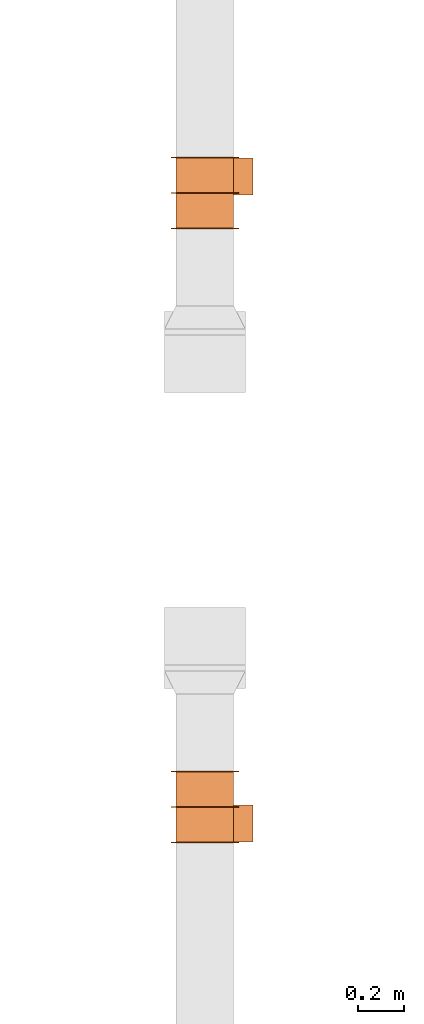
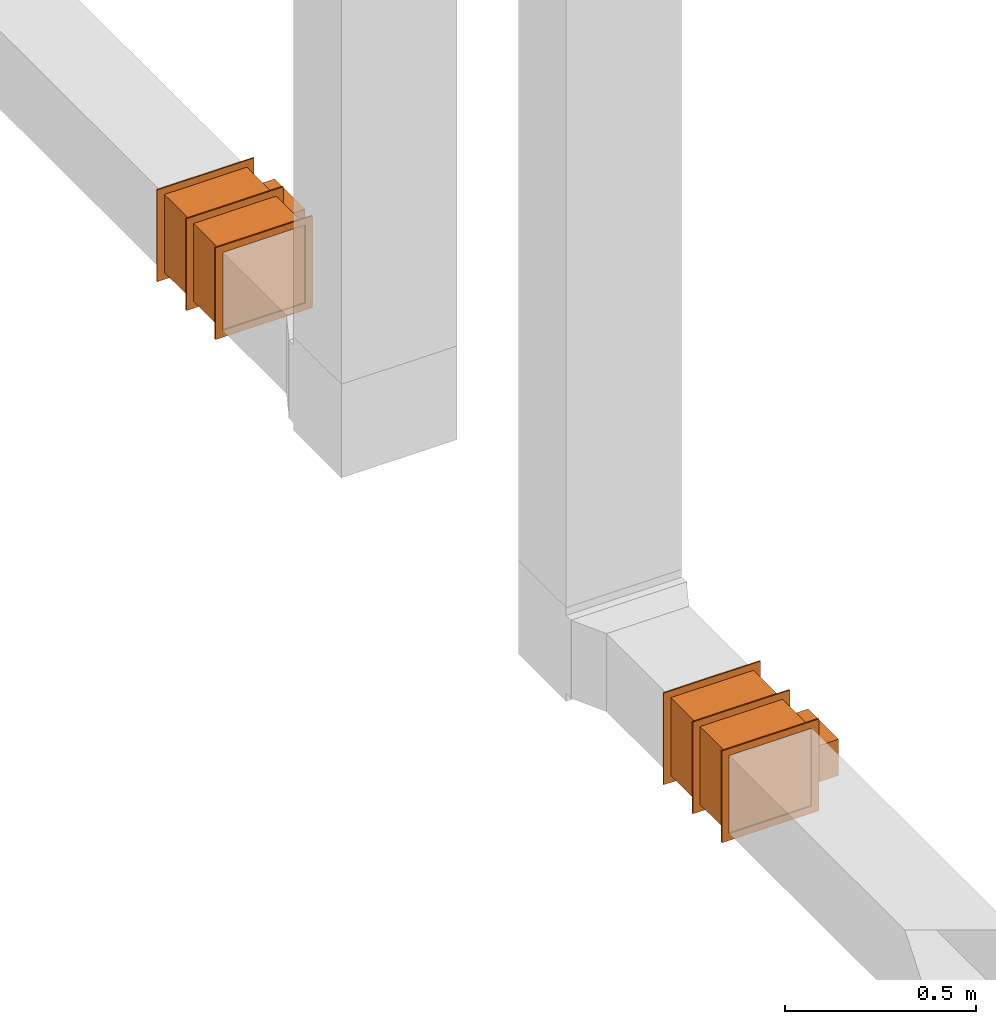
# One storey, part 3 of 3: 2 proxies.
"""IFC2X3 building model written with IfcOpenShell, lengths in millimetres."""

from ifc_helpers import new_model, entity, si_unit, converted_unit, derived_unit, direction, frame, frame_2d, origin, origin_2d_with_axis, place, context, subcontext, project, spatial, polyline, rectangle, outline, extrude, source, transform, mapped, type_object, type_shapes, element, save


model = new_model("IFC2X3")

# Units and contexts
model_context = context("Model", 3, precision=0.01, world=origin(), true_north=direction((6.12303176911189e-17, 1.0)))
body_context = subcontext(model_context, "Body", "Model", "MODEL_VIEW")
ifc_project = project(units=[si_unit("LENGTHUNIT", "METRE", prefix="MILLI"), si_unit("AREAUNIT", "SQUARE_METRE"), si_unit("VOLUMEUNIT", "CUBIC_METRE"), converted_unit("PLANEANGLEUNIT", "DEGREE", entity("IfcRatioMeasure", 0.0174532925199433), si_unit("PLANEANGLEUNIT", "RADIAN"), dimensions=[0, 0, 0, 0, 0, 0, 0]), si_unit("MASSUNIT", "GRAM", prefix="KILO"), derived_unit("MASSDENSITYUNIT", [(si_unit("MASSUNIT", "GRAM", prefix="KILO"), 1), (si_unit("LENGTHUNIT", "METRE"), -3)]), si_unit("TIMEUNIT", "SECOND"), si_unit("FREQUENCYUNIT", "HERTZ"), si_unit("THERMODYNAMICTEMPERATUREUNIT", "DEGREE_CELSIUS"), derived_unit("THERMALTRANSMITTANCEUNIT", [(si_unit("MASSUNIT", "GRAM", prefix="KILO"), 1), (si_unit("THERMODYNAMICTEMPERATUREUNIT", "KELVIN"), -1), (si_unit("TIMEUNIT", "SECOND"), -3)]), derived_unit("VOLUMETRICFLOWRATEUNIT", [(si_unit("LENGTHUNIT", "METRE"), 3), (si_unit("TIMEUNIT", "SECOND"), -1)]), si_unit("ELECTRICCURRENTUNIT", "AMPERE"), si_unit("ELECTRICVOLTAGEUNIT", "VOLT"), si_unit("POWERUNIT", "WATT"), si_unit("FORCEUNIT", "NEWTON", prefix="KILO"), si_unit("ILLUMINANCEUNIT", "LUX"), si_unit("LUMINOUSFLUXUNIT", "LUMEN"), si_unit("LUMINOUSINTENSITYUNIT", "CANDELA"), derived_unit("USERDEFINED", [(si_unit("MASSUNIT", "GRAM", prefix="KILO"), -1), (si_unit("LENGTHUNIT", "METRE"), -2), (si_unit("TIMEUNIT", "SECOND"), 3), (si_unit("LUMINOUSFLUXUNIT", "LUMEN"), 1)]), derived_unit("LINEARVELOCITYUNIT", [(si_unit("LENGTHUNIT", "METRE"), 1), (si_unit("TIMEUNIT", "SECOND"), -1)]), si_unit("PRESSUREUNIT", "PASCAL"), derived_unit("USERDEFINED", [(si_unit("LENGTHUNIT", "METRE"), -2), (si_unit("MASSUNIT", "GRAM", prefix="KILO"), 1), (si_unit("TIMEUNIT", "SECOND"), -2)])], contexts=[model_context])

# Site, building, storey
site_placement = place(None, origin())
site = spatial("IfcSite", under=ifc_project, at=site_placement, CompositionType="ELEMENT")
building_placement = place(site_placement, origin())
building = spatial("IfcBuilding", under=site, at=building_placement, CompositionType="ELEMENT")
storey_placement = place(building_placement, frame((0.0, 0.0, 4000.0)))
storey = spatial("IfcBuildingStorey", under=building, at=storey_placement, Name="01 Level", CompositionType="ELEMENT", Elevation=4000.0)

# Proxies
building_element_proxy_type_1 = type_object("IfcBuildingElementProxyType", Name="WK", PredefinedType="NOTDEFINED")
shared_shape_1 = source(origin(), body_context, "Body", "SweptSolid", [
    extrude(outline(polyline([(-147.0, -147.0), (147.0, -147.0), (147.0, 147.0), (-147.0, 147.0), (-147.0, -147.0)]), holes=[polyline([(-125.0, -125.0), (-125.0, 125.0), (125.0, 125.0), (125.0, -125.0), (-125.0, -125.0)])]), frame((151.0, 0.0, 0.0), z_axis=(1.0, 0.0, 0.0), x_axis=(0.0, 0.0, -1.0)), (0.0, 0.0, 1.0), 4.0),
    extrude(outline(polyline([(-147.0, -147.0), (147.0, -147.0), (147.0, 147.0), (-147.0, 147.0), (-147.0, -147.0)]), holes=[polyline([(-125.0, -125.0), (-125.0, 125.0), (125.0, 125.0), (125.0, -125.0), (-125.0, -125.0)])]), frame((-155.0, 0.0, 0.0), z_axis=(1.0, 0.0, 0.0), x_axis=(0.0, -1.0, 0.0)), (0.0, 0.0, 1.0), 4.0),
    extrude(outline(polyline([(-147.0, -147.0), (147.0, -147.0), (147.0, 147.0), (-147.0, 147.0), (-147.0, -147.0)]), holes=[polyline([(-125.0, -125.0), (-125.0, 125.0), (125.0, 125.0), (125.0, -125.0), (-125.0, -125.0)])]), frame((-2.0, 0.0, 0.0), z_axis=(1.0, 0.0, 0.0), x_axis=(0.0, -1.0, 0.0)), (0.0, 0.0, 1.0), 4.0),
    extrude(rectangle(XDim=302.0, YDim=250.0, at=origin_2d_with_axis()), frame((0.0, 0.0, -125.0), z_axis=(0.0, 0.0, 1.0), x_axis=(-1.0, 0.0, 0.0)), (0.0, 0.0, 1.0), 250.0),
    extrude(rectangle(XDim=84.0, YDim=160.0, at=frame_2d((-1.06581410364015e-14, 0.0), x_axis=(1.0, 0.0))), frame((71.0, -167.0, -58.0), z_axis=(0.0, 0.0, 1.0), x_axis=(0.0, -1.0, 0.0)), (0.0, 0.0, 1.0), 116.0),
])
type_shapes(building_element_proxy_type_1, [shared_shape_1])
proxy_1_placement = place(storey_placement, frame((24630.6615179764, -70160.2893332731, 3510.0), z_axis=(0.0, 0.0, -1.0), x_axis=(0.0, -1.0, 0.0)))
element("IfcBuildingElementProxy", 1, at=proxy_1_placement, inside=storey, type_object=building_element_proxy_type_1, Name="WK25-0001:WK", ObjectType="WK25-0001:WK", context=body_context, shape_type="MappedRepresentation", body=[
    mapped(shared_shape_1, transform((0.0, 0.0, 0.0), scale=1.0)),
])
building_element_proxy_type_2 = type_object("IfcBuildingElementProxyType", Name="WK", PredefinedType="NOTDEFINED")
shared_shape_2 = source(origin(), body_context, "Body", "SweptSolid", [
    extrude(outline(polyline([(-147.0, -147.0), (147.0, -147.0), (147.0, 147.0), (-147.0, 147.0), (-147.0, -147.0)]), holes=[polyline([(-125.0, -125.0), (-125.0, 125.0), (125.0, 125.0), (125.0, -125.0), (-125.0, -125.0)])]), frame((151.0, 0.0, 0.0), z_axis=(1.0, 0.0, 0.0), x_axis=(0.0, -1.0, 0.0)), (0.0, 0.0, 1.0), 4.0),
    extrude(outline(polyline([(-147.0, -147.0), (147.0, -147.0), (147.0, 147.0), (-147.0, 147.0), (-147.0, -147.0)]), holes=[polyline([(-125.0, -125.0), (-125.0, 125.0), (125.0, 125.0), (125.0, -125.0), (-125.0, -125.0)])]), frame((-155.0, 0.0, 0.0), z_axis=(1.0, 0.0, 0.0), x_axis=(0.0, 0.0, -1.0)), (0.0, 0.0, 1.0), 4.0),
    extrude(outline(polyline([(-147.0, -147.0), (147.0, -147.0), (147.0, 147.0), (-147.0, 147.0), (-147.0, -147.0)]), holes=[polyline([(-125.0, -125.0), (-125.0, 125.0), (125.0, 125.0), (125.0, -125.0), (-125.0, -125.0)])]), frame((-2.0, 0.0, 0.0), z_axis=(1.0, 0.0, 0.0), x_axis=(0.0, 0.0, -1.0)), (0.0, 0.0, 1.0), 4.0),
    extrude(rectangle(XDim=250.0, YDim=302.0, at=origin_2d_with_axis()), frame((0.0, 0.0, -125.0), z_axis=(0.0, 0.0, 1.0), x_axis=(0.0, 1.0, 0.0)), (0.0, 0.0, 1.0), 250.0),
    extrude(rectangle(XDim=160.0, YDim=84.0, at=frame_2d((0.0, -1.06581410364015e-14), x_axis=(1.0, 0.0))), frame((71.0, 167.0, -58.0)), (0.0, 0.0, 1.0), 116.0),
])
type_shapes(building_element_proxy_type_2, [shared_shape_2])
proxy_2_placement = place(storey_placement, frame((24630.6615179764, -67502.1898370068, 3510.0), z_axis=(0.0, 0.0, -1.0), x_axis=(0.0, 1.0, 0.0)))
element("IfcBuildingElementProxy", 2, at=proxy_2_placement, inside=storey, type_object=building_element_proxy_type_2, Name="WK25-0001:WK", ObjectType="WK25-0001:WK", context=body_context, shape_type="MappedRepresentation", body=[
    mapped(shared_shape_2, transform((0.0, 0.0, 0.0), scale=1.0)),
])

save(model, "model.ifc")
